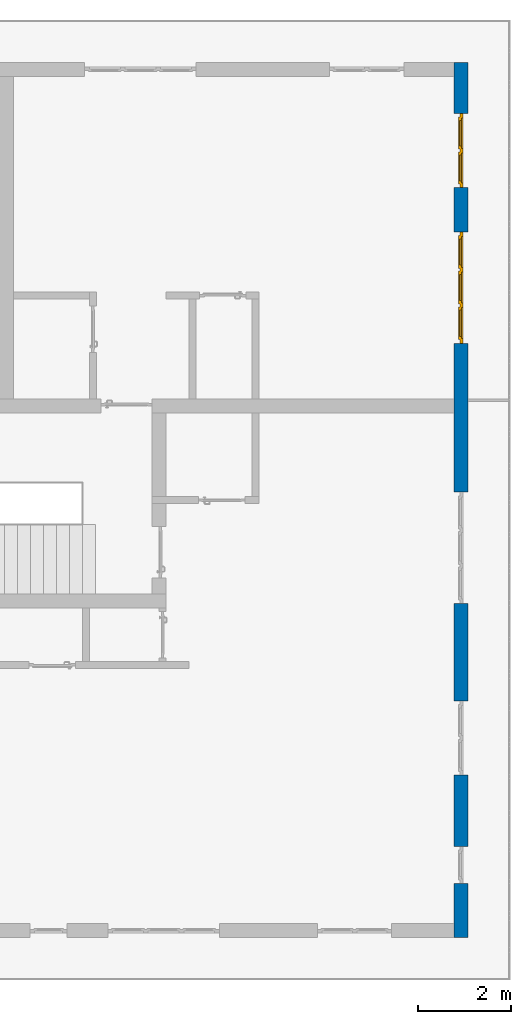
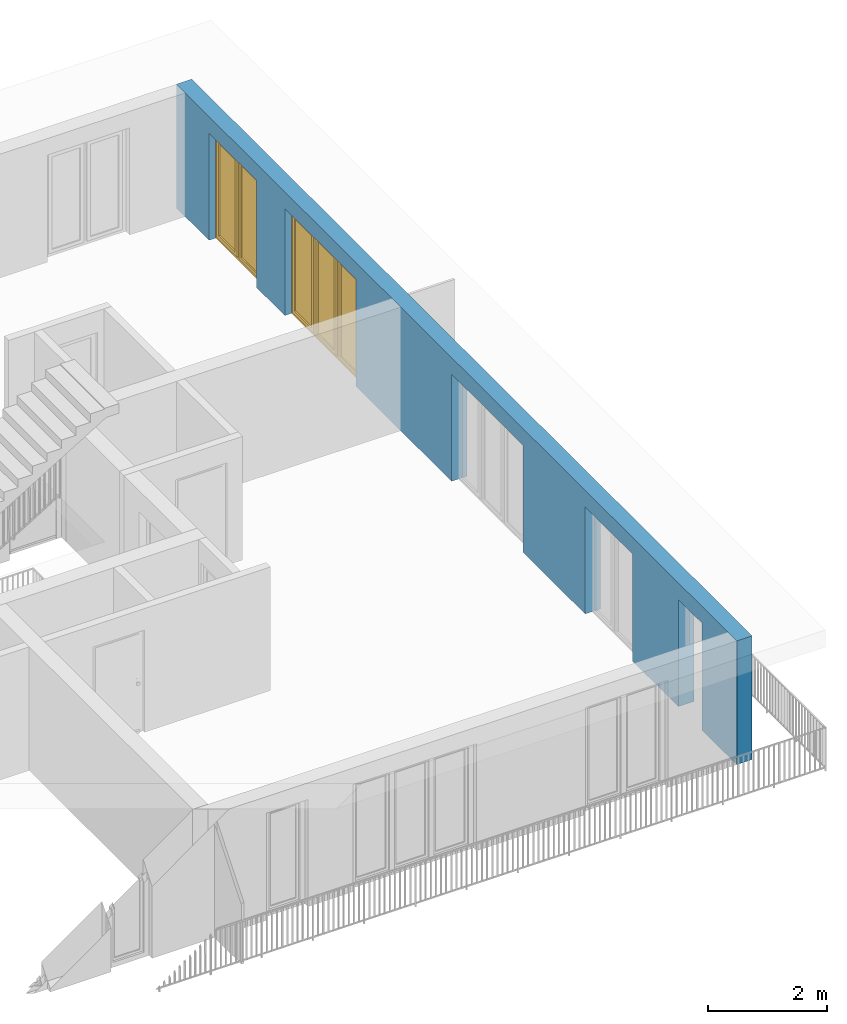
# One storey, part 17 of 48: 2 windows, 1 wall, 5 openings.
"""IFC4 building model written with IfcOpenShell, lengths in metres."""

from ifc_helpers import new_model, entity, si_unit, converted_unit, derived_unit, direction, frame, origin_with_axes, place, context, subcontext, project, spatial, polygons, source, transform, mapped, material, type_object, element, fill, save


model = new_model("IFC4")

# Units and contexts
model_context = context("Model", 3, precision=1e-05, world=origin_with_axes(), true_north=direction((0.0, 1.0)))
body_context = subcontext(model_context, "Body", "Model", "MODEL_VIEW")
ifc_project = project(units=[si_unit("LENGTHUNIT", "METRE"), si_unit("AREAUNIT", "SQUARE_METRE"), si_unit("VOLUMEUNIT", "CUBIC_METRE"), converted_unit("PLANEANGLEUNIT", "DEGREE", entity("IfcPlaneAngleMeasure", 0.0174532925199), si_unit("PLANEANGLEUNIT", "RADIAN"), dimensions=[0, 0, 0, 0, 0, 0, 0]), converted_unit("TIMEUNIT", "Year", entity("IfcTimeMeasure", 31556926.0), si_unit("TIMEUNIT", "SECOND"), dimensions=[0, 0, 1, 0, 0, 0, 0]), si_unit("MASSUNIT", "GRAM", prefix="KILO"), si_unit("THERMODYNAMICTEMPERATUREUNIT", "DEGREE_CELSIUS"), si_unit("LUMINOUSINTENSITYUNIT", "LUMEN"), si_unit("ENERGYUNIT", "JOULE", prefix="MEGA"), derived_unit("THERMALCONDUCTANCEUNIT", [(si_unit("POWERUNIT", "WATT"), 1), (si_unit("LENGTHUNIT", "METRE"), -1), (si_unit("THERMODYNAMICTEMPERATUREUNIT", "KELVIN"), -1)]), derived_unit("SPECIFICHEATCAPACITYUNIT", [(si_unit("ENERGYUNIT", "JOULE"), 1), (si_unit("MASSUNIT", "GRAM", prefix="KILO"), -1), (si_unit("THERMODYNAMICTEMPERATUREUNIT", "KELVIN"), -1)]), derived_unit("MASSDENSITYUNIT", [(si_unit("MASSUNIT", "GRAM", prefix="KILO"), 1), (si_unit("VOLUMEUNIT", "CUBIC_METRE"), -1)])], contexts=[model_context])

# Site, building, storey
site_placement = place(None, origin_with_axes())
site = spatial("IfcSite", under=ifc_project, at=site_placement, CompositionType="ELEMENT")
building_placement = place(site_placement, origin_with_axes())
building = spatial("IfcBuilding", under=site, at=building_placement, CompositionType="ELEMENT")
storey_placement = place(building_placement, frame((0.0, 0.0, 3.4), z_axis=(0.0, 0.0, 1.0), x_axis=(1.0, 0.0, 0.0)))
storey = spatial("IfcBuildingStorey", under=building, at=storey_placement, Name="1. Geschoss", CompositionType="ELEMENT", Elevation=3.4)

# Wall, openings, windows
ifc_material = material()
wall_type = type_object("IfcWallType", Name="300", PredefinedType="NOTDEFINED")
wall_placement = place(storey_placement, frame((9.3378006196, -9.92881223104, 0.0), z_axis=(0.0, 0.0, 1.0), x_axis=(0.0, 1.0, 0.0)))
wall = element("IfcWall", 1, at=wall_placement, inside=storey, type_object=wall_type, material=ifc_material, Name="Wand-001", PredefinedType="NOTDEFINED", context=body_context, shape_type="Tessellation", body=[
    polygons([(1.16441876325, 0.1, 2.2), (1.96441876325, 0.1, 2.2), (1.96441876325, 0.0, 2.2), (1.16441876325, 0.0, 2.2), (1.16441876325, 0.3, 2.2), (1.96441876325, 0.3, 2.2), (1.96441876325, 0.1, 0.0), (1.96441876325, 0.0, 0.0), (18.85, 0.0, 2.54), (0.0, 0.0, 2.54), (0.0, 0.0, 0.0), (1.16441876325, 0.0, 0.0), (3.5, 0.0, 0.0), (3.5, 0.0, 2.2), (5.1, 0.0, 2.2), (5.1, 0.0, 0.0), (7.1921181063, 0.0, 0.0), (7.1921181063, 0.0, 2.2), (9.5921181063, 0.0, 2.2), (9.5921181063, 0.0, 0.0), (12.8, 0.0, 0.0), (12.8, 0.0, 2.2), (15.2, 0.0, 2.2), (15.2, 0.0, 0.0), (16.15, 0.0, 0.0), (16.15, 0.0, 2.2), (17.75, 0.0, 2.2), (17.75, 0.0, 0.0), (18.85, 0.0, 0.0), (1.16441876325, 0.1, 0.0), (1.16441876325, 0.3, 0.0), (0.0, 0.3, 0.0), (0.0, 0.3, 2.54), (18.85, 0.3, 2.54), (18.85, 0.3, 0.0), (17.75, 0.3, 0.0), (17.75, 0.3, 2.2), (16.15, 0.3, 2.2), (16.15, 0.3, 0.0), (15.2, 0.3, 0.0), (15.2, 0.3, 2.2), (12.8, 0.3, 2.2), (12.8, 0.3, 0.0), (9.5921181063, 0.3, 0.0), (9.5921181063, 0.3, 2.2), (7.1921181063, 0.3, 2.2), (7.1921181063, 0.3, 0.0), (5.1, 0.3, 0.0), (5.1, 0.3, 2.2), (3.5, 0.3, 2.2), (3.5, 0.3, 0.0), (1.96441876325, 0.3, 0.0), (3.5, 0.1, 0.0), (3.5, 0.1, 2.2), (5.1, 0.1, 2.2), (5.1, 0.1, 0.0), (7.1921181063, 0.1, 0.0), (7.1921181063, 0.1, 2.2), (9.5921181063, 0.1, 2.2), (9.5921181063, 0.1, 0.0), (12.8, 0.1, 0.0), (12.8, 0.1, 2.2), (15.2, 0.1, 2.2), (15.2, 0.1, 0.0), (16.15, 0.1, 0.0), (16.15, 0.1, 2.2), (17.75, 0.1, 2.2), (17.75, 0.1, 0.0)], [[[1, 2, 3, 4]], [[2, 1, 5, 6]], [[2, 7, 8, 3]], [[9, 10, 11, 12, 4, 3, 8, 13, 14, 15, 16, 17, 18, 19, 20, 21, 22, 23, 24, 25, 26, 27, 28, 29]], [[30, 1, 4, 12]], [[1, 30, 31, 5]], [[5, 31, 32, 33, 34, 35, 36, 37, 38, 39, 40, 41, 42, 43, 44, 45, 46, 47, 48, 49, 50, 51, 52, 6]], [[7, 2, 6, 52]], [[7, 52, 51, 53, 13, 8]], [[9, 34, 33, 10]], [[33, 32, 11, 10]], [[31, 30, 12, 11, 32]], [[14, 13, 53, 54]], [[15, 14, 54, 55]], [[16, 15, 55, 56]], [[56, 48, 47, 57, 17, 16]], [[57, 58, 18, 17]], [[58, 59, 19, 18]], [[59, 60, 20, 19]], [[60, 44, 43, 61, 21, 20]], [[22, 21, 61, 62]], [[23, 22, 62, 63]], [[24, 23, 63, 64]], [[64, 40, 39, 65, 25, 24]], [[65, 66, 26, 25]], [[66, 67, 27, 26]], [[67, 68, 28, 27]], [[36, 35, 29, 28, 68]], [[9, 29, 35, 34]], [[68, 67, 37, 36]], [[67, 66, 38, 37]], [[66, 65, 39, 38]], [[41, 40, 64, 63]], [[42, 41, 63, 62]], [[43, 42, 62, 61]], [[60, 59, 45, 44]], [[59, 58, 46, 45]], [[58, 57, 47, 46]], [[49, 48, 56, 55]], [[50, 49, 55, 54]], [[51, 50, 54, 53]]], closed=True),
])
opening_1_placement = place(wall_placement, frame((16.95, 0.0, 0.0), z_axis=(0.0, 0.0, 1.0), x_axis=(1.0, 0.0, 0.0)))
opening_1 = element("IfcOpeningElement", 2, at=opening_1_placement, cuts=wall, Name="Fenster-001", context=body_context, identifier="Reference", shape_type="Tessellation", body=[
    polygons([(0.8, 0.1, 0.0), (0.8, 0.1, 2.2), (0.8, -0.000999999999999, 2.2), (0.8, -0.000999999999999, 0.0), (0.8, 0.301, 0.0), (0.8, 0.301, 2.2), (-0.8, 0.1, 2.2), (-0.8, -0.000999999999999, 2.2), (-0.8, 0.301, 2.2), (-0.8, -0.000999999999999, 0.0), (-0.8, 0.1, 0.0), (-0.8, 0.301, 0.0)], [[[1, 2, 3, 4]], [[2, 1, 5, 6]], [[7, 8, 3, 2, 6, 9]], [[8, 10, 4, 3]], [[1, 4, 10, 11, 12, 5]], [[6, 5, 12, 9]], [[7, 11, 10, 8]], [[11, 7, 9, 12]]], closed=True),
])
opening_2_placement = place(wall_placement, frame((14.0, 0.0, 0.0), z_axis=(0.0, 0.0, 1.0), x_axis=(1.0, 0.0, 0.0)))
opening_2 = element("IfcOpeningElement", 3, at=opening_2_placement, cuts=wall, Name="Fenster-002", context=body_context, identifier="Reference", shape_type="Tessellation", body=[
    polygons([(1.2, 0.1, 0.0), (1.2, 0.1, 2.2), (1.2, -0.000999999999999, 2.2), (1.2, -0.000999999999999, 0.0), (1.2, 0.301, 0.0), (1.2, 0.301, 2.2), (-1.2, 0.1, 2.2), (-1.2, -0.000999999999999, 2.2), (-1.2, 0.301, 2.2), (-1.2, -0.000999999999999, 0.0), (-1.2, 0.1, 0.0), (-1.2, 0.301, 0.0)], [[[1, 2, 3, 4]], [[2, 1, 5, 6]], [[7, 8, 3, 2, 6, 9]], [[8, 10, 4, 3]], [[1, 4, 10, 11, 12, 5]], [[6, 5, 12, 9]], [[7, 11, 10, 8]], [[11, 7, 9, 12]]], closed=True),
])
opening_3_placement = place(wall_placement, frame((8.3921181063, 0.0, 0.0), z_axis=(0.0, 0.0, 1.0), x_axis=(1.0, 0.0, 0.0)))
element("IfcOpeningElement", 4, at=opening_3_placement, cuts=wall, Name="Fenster-002", context=body_context, identifier="Reference", shape_type="Tessellation", body=[
    polygons([(1.2, 0.1, 0.0), (1.2, 0.1, 2.2), (1.2, -0.000999999999999, 2.2), (1.2, -0.000999999999999, 0.0), (1.2, 0.301, 0.0), (1.2, 0.301, 2.2), (-1.2, 0.1, 2.2), (-1.2, -0.000999999999999, 2.2), (-1.2, 0.301, 2.2), (-1.2, -0.000999999999999, 0.0), (-1.2, 0.1, 0.0), (-1.2, 0.301, 0.0)], [[[1, 2, 3, 4]], [[2, 1, 5, 6]], [[7, 8, 3, 2, 6, 9]], [[8, 10, 4, 3]], [[1, 4, 10, 11, 12, 5]], [[6, 5, 12, 9]], [[7, 11, 10, 8]], [[11, 7, 9, 12]]], closed=True),
])
opening_4_placement = place(wall_placement, frame((4.3, 0.0, 0.0), z_axis=(0.0, 0.0, 1.0), x_axis=(1.0, 0.0, 0.0)))
element("IfcOpeningElement", 5, at=opening_4_placement, cuts=wall, Name="Fenster-001", context=body_context, identifier="Reference", shape_type="Tessellation", body=[
    polygons([(0.8, 0.1, 0.0), (0.8, 0.1, 2.2), (0.8, -0.000999999999999, 2.2), (0.8, -0.000999999999999, 0.0), (0.8, 0.301, 0.0), (0.8, 0.301, 2.2), (-0.8, 0.1, 2.2), (-0.8, -0.000999999999999, 2.2), (-0.8, 0.301, 2.2), (-0.8, -0.000999999999999, 0.0), (-0.8, 0.1, 0.0), (-0.8, 0.301, 0.0)], [[[1, 2, 3, 4]], [[2, 1, 5, 6]], [[7, 8, 3, 2, 6, 9]], [[8, 10, 4, 3]], [[1, 4, 10, 11, 12, 5]], [[6, 5, 12, 9]], [[7, 11, 10, 8]], [[11, 7, 9, 12]]], closed=True),
])
opening_5_placement = place(wall_placement, frame((1.56441876325, 0.0, 0.0), z_axis=(0.0, 0.0, 1.0), x_axis=(1.0, 0.0, 0.0)))
element("IfcOpeningElement", 6, at=opening_5_placement, cuts=wall, Name="Fenster-003", context=body_context, identifier="Reference", shape_type="Tessellation", body=[
    polygons([(0.4, 0.1, 0.0), (0.4, 0.1, 2.2), (0.4, -0.000999999999999, 2.2), (0.4, -0.000999999999999, 0.0), (0.4, 0.301, 0.0), (0.4, 0.301, 2.2), (-0.4, 0.1, 2.2), (-0.4, -0.000999999999999, 2.2), (-0.4, 0.301, 2.2), (-0.4, -0.000999999999999, 0.0), (-0.4, 0.1, 0.0), (-0.4, 0.301, 0.0)], [[[1, 2, 3, 4]], [[2, 1, 5, 6]], [[7, 8, 3, 2, 6, 9]], [[8, 10, 4, 3]], [[1, 4, 10, 11, 12, 5]], [[6, 5, 12, 9]], [[7, 11, 10, 8]], [[11, 7, 9, 12]]], closed=True),
])
window_type_1 = type_object("IfcWindowType", Name="2-1+1 26", PartitioningType="DOUBLE_PANEL_VERTICAL", PredefinedType="WINDOW")
shared_shape_1 = source(origin_with_axes(), body_context, "Body", "Tessellation", [
    polygons([(-0.8, -0.07, 0.0), (-0.8, 0.0, 0.0), (-0.7, 0.0, 0.1), (-0.7, -0.07, 0.1), (-0.8, -0.07, 2.2), (-0.8, 0.0, 2.2), (-0.7, 0.0, 2.1), (-0.7, -0.07, 2.1)], [[[1, 2, 3, 4]], [[5, 6, 2, 1]], [[2, 6, 7, 3]], [[4, 3, 7, 8]], [[1, 4, 8, 5]], [[8, 7, 6, 5]]], closed=True),
    polygons([(0.8, -0.07, 0.0), (0.8, 0.0, 0.0), (0.8, 0.0, 2.2), (0.8, -0.07, 2.2), (0.7, -0.07, 0.1), (0.7, 0.0, 0.1), (0.7, 0.0, 2.1), (0.7, -0.07, 2.1)], [[[1, 2, 3, 4]], [[5, 6, 2, 1]], [[2, 6, 7, 3]], [[4, 3, 7, 8]], [[1, 4, 8, 5]], [[8, 7, 6, 5]]], closed=True),
    polygons([(-0.8, -0.07, 0.0), (-0.8, 0.0, 0.0), (0.8, 0.0, 0.0), (0.8, -0.07, 0.0), (-0.7, -0.07, 0.1), (-0.7, 0.0, 0.1), (-0.05, 0.0, 0.1), (0.05, 0.0, 0.1), (0.7, 0.0, 0.1), (0.7, -0.07, 0.1), (0.05, -0.07, 0.1), (-0.05, -0.07, 0.1)], [[[1, 2, 3, 4]], [[5, 6, 2, 1]], [[2, 6, 7, 8, 9, 3]], [[4, 3, 9, 10]], [[1, 4, 10, 11, 12, 5]], [[12, 7, 6, 5]], [[11, 8, 7, 12]], [[10, 9, 8, 11]]], closed=True),
    polygons([(-0.8, -0.07, 2.2), (-0.8, 0.0, 2.2), (-0.7, 0.0, 2.1), (-0.7, -0.07, 2.1), (0.8, -0.07, 2.2), (0.8, 0.0, 2.2), (0.7, 0.0, 2.1), (0.05, 0.0, 2.1), (-0.05, 0.0, 2.1), (-0.05, -0.07, 2.1), (0.05, -0.07, 2.1), (0.7, -0.07, 2.1)], [[[1, 2, 3, 4]], [[5, 6, 2, 1]], [[2, 6, 7, 8, 9, 3]], [[4, 3, 9, 10]], [[1, 4, 10, 11, 12, 5]], [[12, 7, 6, 5]], [[11, 8, 7, 12]], [[10, 9, 8, 11]]], closed=True),
    polygons([(-0.05, -0.07, 0.1), (-0.05, 0.0, 0.1), (0.05, 0.0, 0.1), (0.05, -0.07, 0.1), (-0.05, -0.07, 2.1), (-0.05, 0.0, 2.1), (0.05, 0.0, 2.1), (0.05, -0.07, 2.1)], [[[1, 2, 3, 4]], [[5, 6, 2, 1]], [[2, 6, 7, 3]], [[4, 3, 7, 8]], [[1, 4, 8, 5]], [[8, 7, 6, 5]]], closed=True),
    polygons([(-0.72, 0.0, 0.08), (-0.72, 0.03, 0.08), (-0.65, 0.03, 0.15), (-0.65, 0.0, 0.15), (-0.72, 0.0, 2.12), (-0.72, 0.03, 2.12), (-0.65, 0.03, 2.05), (-0.65, 0.0, 2.05)], [[[1, 2, 3, 4]], [[5, 6, 2, 1]], [[2, 6, 7, 3]], [[4, 3, 7, 8]], [[1, 4, 8, 5]], [[8, 7, 6, 5]]], closed=True),
    polygons([(-0.03, 0.0, 0.08), (-0.1, 0.0, 0.15), (-0.1, 0.03, 0.15), (-0.03, 0.03, 0.08), (-0.03, 0.0, 2.12), (-0.1, 0.0, 2.05), (-0.1, 0.03, 2.05), (-0.03, 0.03, 2.12)], [[[1, 2, 3, 4]], [[1, 5, 6, 2]], [[2, 6, 7, 3]], [[4, 3, 7, 8]], [[5, 1, 4, 8]], [[6, 5, 8, 7]]], closed=True),
    polygons([(-0.72, 0.0, 0.08), (-0.72, 0.03, 0.08), (-0.03, 0.03, 0.08), (-0.03, 0.0, 0.08), (-0.65, 0.0, 0.15), (-0.65, 0.03, 0.15), (-0.1, 0.03, 0.15), (-0.1, 0.0, 0.15)], [[[1, 2, 3, 4]], [[5, 6, 2, 1]], [[2, 6, 7, 3]], [[4, 3, 7, 8]], [[1, 4, 8, 5]], [[8, 7, 6, 5]]], closed=True),
    polygons([(-0.72, 0.0, 2.12), (-0.03, 0.0, 2.12), (-0.03, 0.03, 2.12), (-0.72, 0.03, 2.12), (-0.65, 0.0, 2.05), (-0.1, 0.0, 2.05), (-0.1, 0.03, 2.05), (-0.65, 0.03, 2.05)], [[[1, 2, 3, 4]], [[1, 5, 6, 2]], [[2, 6, 7, 3]], [[4, 3, 7, 8]], [[5, 1, 4, 8]], [[6, 5, 8, 7]]], closed=True),
    polygons([(-0.7, -0.03, 0.1), (-0.7, 0.0, 0.1), (-0.65, 0.0, 0.15), (-0.65, -0.03, 0.15), (-0.7, -0.03, 2.1), (-0.7, 0.0, 2.1), (-0.65, 0.0, 2.05), (-0.65, -0.03, 2.05)], [[[1, 2, 3, 4]], [[5, 6, 2, 1]], [[2, 6, 7, 3]], [[4, 3, 7, 8]], [[1, 4, 8, 5]], [[8, 7, 6, 5]]], closed=True),
    polygons([(-0.05, -0.03, 0.1), (-0.1, -0.03, 0.15), (-0.1, 0.0, 0.15), (-0.05, 0.0, 0.1), (-0.05, -0.03, 2.1), (-0.1, -0.03, 2.05), (-0.1, 0.0, 2.05), (-0.05, 0.0, 2.1)], [[[1, 2, 3, 4]], [[1, 5, 6, 2]], [[2, 6, 7, 3]], [[4, 3, 7, 8]], [[5, 1, 4, 8]], [[6, 5, 8, 7]]], closed=True),
    polygons([(-0.7, -0.03, 0.1), (-0.7, 0.0, 0.1), (-0.05, 0.0, 0.1), (-0.05, -0.03, 0.1), (-0.65, -0.03, 0.15), (-0.65, 0.0, 0.15), (-0.1, 0.0, 0.15), (-0.1, -0.03, 0.15)], [[[1, 2, 3, 4]], [[5, 6, 2, 1]], [[2, 6, 7, 3]], [[4, 3, 7, 8]], [[1, 4, 8, 5]], [[8, 7, 6, 5]]], closed=True),
    polygons([(-0.7, -0.03, 2.1), (-0.05, -0.03, 2.1), (-0.05, 0.0, 2.1), (-0.7, 0.0, 2.1), (-0.65, -0.03, 2.05), (-0.1, -0.03, 2.05), (-0.1, 0.0, 2.05), (-0.65, 0.0, 2.05)], [[[1, 2, 3, 4]], [[1, 5, 6, 2]], [[2, 6, 7, 3]], [[4, 3, 7, 8]], [[5, 1, 4, 8]], [[6, 5, 8, 7]]], closed=True),
    polygons([(-0.65, -0.005, 0.15), (-0.65, 0.005, 0.15), (-0.1, 0.005, 0.15), (-0.1, -0.005, 0.15), (-0.65, -0.005, 2.05), (-0.65, 0.005, 2.05), (-0.1, 0.005, 2.05), (-0.1, -0.005, 2.05)], [[[1, 2, 3, 4]], [[5, 6, 2, 1]], [[2, 6, 7, 3]], [[4, 3, 7, 8]], [[1, 4, 8, 5]], [[8, 7, 6, 5]]], closed=True),
    polygons([(0.03, 0.0, 0.08), (0.03, 0.03, 0.08), (0.1, 0.03, 0.15), (0.1, 0.0, 0.15), (0.03, 0.0, 2.12), (0.03, 0.03, 2.12), (0.1, 0.03, 2.05), (0.1, 0.0, 2.05)], [[[1, 2, 3, 4]], [[5, 6, 2, 1]], [[2, 6, 7, 3]], [[4, 3, 7, 8]], [[1, 4, 8, 5]], [[8, 7, 6, 5]]], closed=True),
    polygons([(0.72, 0.0, 0.08), (0.65, 0.0, 0.15), (0.65, 0.03, 0.15), (0.72, 0.03, 0.08), (0.72, 0.0, 2.12), (0.65, 0.0, 2.05), (0.65, 0.03, 2.05), (0.72, 0.03, 2.12)], [[[1, 2, 3, 4]], [[1, 5, 6, 2]], [[2, 6, 7, 3]], [[4, 3, 7, 8]], [[5, 1, 4, 8]], [[6, 5, 8, 7]]], closed=True),
    polygons([(0.03, 0.0, 0.08), (0.03, 0.03, 0.08), (0.72, 0.03, 0.08), (0.72, 0.0, 0.08), (0.1, 0.0, 0.15), (0.1, 0.03, 0.15), (0.65, 0.03, 0.15), (0.65, 0.0, 0.15)], [[[1, 2, 3, 4]], [[5, 6, 2, 1]], [[2, 6, 7, 3]], [[4, 3, 7, 8]], [[1, 4, 8, 5]], [[8, 7, 6, 5]]], closed=True),
    polygons([(0.03, 0.0, 2.12), (0.72, 0.0, 2.12), (0.72, 0.03, 2.12), (0.03, 0.03, 2.12), (0.1, 0.0, 2.05), (0.65, 0.0, 2.05), (0.65, 0.03, 2.05), (0.1, 0.03, 2.05)], [[[1, 2, 3, 4]], [[1, 5, 6, 2]], [[2, 6, 7, 3]], [[4, 3, 7, 8]], [[5, 1, 4, 8]], [[6, 5, 8, 7]]], closed=True),
    polygons([(0.05, -0.03, 0.1), (0.05, 0.0, 0.1), (0.1, 0.0, 0.15), (0.1, -0.03, 0.15), (0.05, -0.03, 2.1), (0.05, 0.0, 2.1), (0.1, 0.0, 2.05), (0.1, -0.03, 2.05)], [[[1, 2, 3, 4]], [[5, 6, 2, 1]], [[2, 6, 7, 3]], [[4, 3, 7, 8]], [[1, 4, 8, 5]], [[8, 7, 6, 5]]], closed=True),
    polygons([(0.7, -0.03, 0.1), (0.65, -0.03, 0.15), (0.65, 0.0, 0.15), (0.7, 0.0, 0.1), (0.7, -0.03, 2.1), (0.65, -0.03, 2.05), (0.65, 0.0, 2.05), (0.7, 0.0, 2.1)], [[[1, 2, 3, 4]], [[1, 5, 6, 2]], [[2, 6, 7, 3]], [[4, 3, 7, 8]], [[5, 1, 4, 8]], [[6, 5, 8, 7]]], closed=True),
    polygons([(0.05, -0.03, 0.1), (0.05, 0.0, 0.1), (0.7, 0.0, 0.1), (0.7, -0.03, 0.1), (0.1, -0.03, 0.15), (0.1, 0.0, 0.15), (0.65, 0.0, 0.15), (0.65, -0.03, 0.15)], [[[1, 2, 3, 4]], [[5, 6, 2, 1]], [[2, 6, 7, 3]], [[4, 3, 7, 8]], [[1, 4, 8, 5]], [[8, 7, 6, 5]]], closed=True),
    polygons([(0.05, -0.03, 2.1), (0.7, -0.03, 2.1), (0.7, 0.0, 2.1), (0.05, 0.0, 2.1), (0.1, -0.03, 2.05), (0.65, -0.03, 2.05), (0.65, 0.0, 2.05), (0.1, 0.0, 2.05)], [[[1, 2, 3, 4]], [[1, 5, 6, 2]], [[2, 6, 7, 3]], [[4, 3, 7, 8]], [[5, 1, 4, 8]], [[6, 5, 8, 7]]], closed=True),
    polygons([(0.1, -0.005, 0.15), (0.1, 0.005, 0.15), (0.65, 0.005, 0.15), (0.65, -0.005, 0.15), (0.1, -0.005, 2.05), (0.1, 0.005, 2.05), (0.65, 0.005, 2.05), (0.65, -0.005, 2.05)], [[[1, 2, 3, 4]], [[5, 6, 2, 1]], [[2, 6, 7, 3]], [[4, 3, 7, 8]], [[1, 4, 8, 5]], [[8, 7, 6, 5]]], closed=True),
])
window_1_placement = place(opening_1_placement, frame((-0.8, 0.0, 0.0), z_axis=(0.0, 0.0, 1.0), x_axis=(1.0, 0.0, 0.0)))
window_1 = element("IfcWindow", 7, at=window_1_placement, inside=storey, type_object=window_type_1, Name="Fenster-001", OverallHeight=2.2, OverallWidth=1.6, PredefinedType="WINDOW", context=body_context, shape_type="MappedRepresentation", body=[
    mapped(shared_shape_1, transform((0.8, 0.17, 0.0))),
])
fill(opening_1, window_1)
window_type_2 = type_object("IfcWindowType", Name="3-1+1+1 26", PartitioningType="TRIPLE_PANEL_VERTICAL", PredefinedType="WINDOW")
shared_shape_2 = source(origin_with_axes(), body_context, "Body", "Tessellation", [
    polygons([(1.2, -0.07, 0.0), (1.1, -0.07, 0.1), (1.1, 0.0, 0.1), (1.2, 0.0, 0.0), (1.2, -0.07, 2.2), (1.1, -0.07, 2.1), (1.1, 0.0, 2.1), (1.2, 0.0, 2.2)], [[[1, 2, 3, 4]], [[1, 5, 6, 2]], [[2, 6, 7, 3]], [[4, 3, 7, 8]], [[5, 1, 4, 8]], [[6, 5, 8, 7]]], closed=True),
    polygons([(-1.2, -0.07, 0.0), (-1.2, -0.07, 2.2), (-1.2, 0.0, 2.2), (-1.2, 0.0, 0.0), (-1.1, -0.07, 0.1), (-1.1, -0.07, 2.1), (-1.1, 0.0, 2.1), (-1.1, 0.0, 0.1)], [[[1, 2, 3, 4]], [[1, 5, 6, 2]], [[2, 6, 7, 3]], [[4, 3, 7, 8]], [[5, 1, 4, 8]], [[6, 5, 8, 7]]], closed=True),
    polygons([(1.2, -0.07, 0.0), (-1.2, -0.07, 0.0), (-1.2, 0.0, 0.0), (1.2, 0.0, 0.0), (1.1, -0.07, 0.1), (0.433333333333, -0.07, 0.1), (0.333333333333, -0.07, 0.1), (-0.333333333333, -0.07, 0.1), (-0.433333333333, -0.07, 0.1), (-1.1, -0.07, 0.1), (-1.1, 0.0, 0.1), (-0.433333333333, 0.0, 0.1), (-0.333333333333, 0.0, 0.1), (0.333333333333, 0.0, 0.1), (0.433333333333, 0.0, 0.1), (1.1, 0.0, 0.1)], [[[1, 2, 3, 4]], [[1, 5, 6, 7, 8, 9, 10, 2]], [[2, 10, 11, 3]], [[4, 3, 11, 12, 13, 14, 15, 16]], [[5, 1, 4, 16]], [[6, 5, 16, 15]], [[7, 6, 15, 14]], [[8, 7, 14, 13]], [[9, 8, 13, 12]], [[10, 9, 12, 11]]], closed=True),
    polygons([(1.2, -0.07, 2.2), (1.1, -0.07, 2.1), (1.1, 0.0, 2.1), (1.2, 0.0, 2.2), (-1.2, -0.07, 2.2), (-1.1, -0.07, 2.1), (-0.433333333333, -0.07, 2.1), (-0.333333333333, -0.07, 2.1), (0.333333333333, -0.07, 2.1), (0.433333333333, -0.07, 2.1), (0.433333333333, 0.0, 2.1), (0.333333333333, 0.0, 2.1), (-0.333333333333, 0.0, 2.1), (-0.433333333333, 0.0, 2.1), (-1.1, 0.0, 2.1), (-1.2, 0.0, 2.2)], [[[1, 2, 3, 4]], [[1, 5, 6, 7, 8, 9, 10, 2]], [[2, 10, 11, 3]], [[4, 3, 11, 12, 13, 14, 15, 16]], [[5, 1, 4, 16]], [[6, 5, 16, 15]], [[7, 6, 15, 14]], [[8, 7, 14, 13]], [[9, 8, 13, 12]], [[10, 9, 12, 11]]], closed=True),
    polygons([(-0.333333333333, -0.07, 0.1), (-0.433333333333, -0.07, 0.1), (-0.433333333333, 0.0, 0.1), (-0.333333333333, 0.0, 0.1), (-0.333333333333, -0.07, 2.1), (-0.433333333333, -0.07, 2.1), (-0.433333333333, 0.0, 2.1), (-0.333333333333, 0.0, 2.1)], [[[1, 2, 3, 4]], [[1, 5, 6, 2]], [[2, 6, 7, 3]], [[4, 3, 7, 8]], [[5, 1, 4, 8]], [[6, 5, 8, 7]]], closed=True),
    polygons([(0.433333333333, -0.07, 0.1), (0.333333333333, -0.07, 0.1), (0.333333333333, 0.0, 0.1), (0.433333333333, 0.0, 0.1), (0.433333333333, -0.07, 2.1), (0.333333333333, -0.07, 2.1), (0.333333333333, 0.0, 2.1), (0.433333333333, 0.0, 2.1)], [[[1, 2, 3, 4]], [[1, 5, 6, 2]], [[2, 6, 7, 3]], [[4, 3, 7, 8]], [[5, 1, 4, 8]], [[6, 5, 8, 7]]], closed=True),
    polygons([(1.12, 0.0, 0.08), (1.05, 0.0, 0.15), (1.05, 0.03, 0.15), (1.12, 0.03, 0.08), (1.12, 0.0, 2.12), (1.05, 0.0, 2.05), (1.05, 0.03, 2.05), (1.12, 0.03, 2.12)], [[[1, 2, 3, 4]], [[1, 5, 6, 2]], [[2, 6, 7, 3]], [[4, 3, 7, 8]], [[5, 1, 4, 8]], [[6, 5, 8, 7]]], closed=True),
    polygons([(0.413333333333, 0.0, 0.08), (0.413333333333, 0.03, 0.08), (0.483333333333, 0.03, 0.15), (0.483333333333, 0.0, 0.15), (0.413333333333, 0.0, 2.12), (0.413333333333, 0.03, 2.12), (0.483333333333, 0.03, 2.05), (0.483333333333, 0.0, 2.05)], [[[1, 2, 3, 4]], [[5, 6, 2, 1]], [[2, 6, 7, 3]], [[4, 3, 7, 8]], [[1, 4, 8, 5]], [[8, 7, 6, 5]]], closed=True),
    polygons([(1.12, 0.0, 0.08), (0.413333333333, 0.0, 0.08), (0.413333333333, 0.03, 0.08), (1.12, 0.03, 0.08), (1.05, 0.0, 0.15), (0.483333333333, 0.0, 0.15), (0.483333333333, 0.03, 0.15), (1.05, 0.03, 0.15)], [[[1, 2, 3, 4]], [[1, 5, 6, 2]], [[2, 6, 7, 3]], [[4, 3, 7, 8]], [[5, 1, 4, 8]], [[6, 5, 8, 7]]], closed=True),
    polygons([(1.12, 0.0, 2.12), (1.12, 0.03, 2.12), (0.413333333333, 0.03, 2.12), (0.413333333333, 0.0, 2.12), (1.05, 0.0, 2.05), (1.05, 0.03, 2.05), (0.483333333333, 0.03, 2.05), (0.483333333333, 0.0, 2.05)], [[[1, 2, 3, 4]], [[5, 6, 2, 1]], [[2, 6, 7, 3]], [[4, 3, 7, 8]], [[1, 4, 8, 5]], [[8, 7, 6, 5]]], closed=True),
    polygons([(1.1, -0.03, 0.1), (1.05, -0.03, 0.15), (1.05, 0.0, 0.15), (1.1, 0.0, 0.1), (1.1, -0.03, 2.1), (1.05, -0.03, 2.05), (1.05, 0.0, 2.05), (1.1, 0.0, 2.1)], [[[1, 2, 3, 4]], [[1, 5, 6, 2]], [[2, 6, 7, 3]], [[4, 3, 7, 8]], [[5, 1, 4, 8]], [[6, 5, 8, 7]]], closed=True),
    polygons([(0.433333333333, -0.03, 0.1), (0.433333333333, 0.0, 0.1), (0.483333333333, 0.0, 0.15), (0.483333333333, -0.03, 0.15), (0.433333333333, -0.03, 2.1), (0.433333333333, 0.0, 2.1), (0.483333333333, 0.0, 2.05), (0.483333333333, -0.03, 2.05)], [[[1, 2, 3, 4]], [[5, 6, 2, 1]], [[2, 6, 7, 3]], [[4, 3, 7, 8]], [[1, 4, 8, 5]], [[8, 7, 6, 5]]], closed=True),
    polygons([(1.1, -0.03, 0.1), (0.433333333333, -0.03, 0.1), (0.433333333333, 0.0, 0.1), (1.1, 0.0, 0.1), (1.05, -0.03, 0.15), (0.483333333333, -0.03, 0.15), (0.483333333333, 0.0, 0.15), (1.05, 0.0, 0.15)], [[[1, 2, 3, 4]], [[1, 5, 6, 2]], [[2, 6, 7, 3]], [[4, 3, 7, 8]], [[5, 1, 4, 8]], [[6, 5, 8, 7]]], closed=True),
    polygons([(1.1, -0.03, 2.1), (1.1, 0.0, 2.1), (0.433333333333, 0.0, 2.1), (0.433333333333, -0.03, 2.1), (1.05, -0.03, 2.05), (1.05, 0.0, 2.05), (0.483333333333, 0.0, 2.05), (0.483333333333, -0.03, 2.05)], [[[1, 2, 3, 4]], [[5, 6, 2, 1]], [[2, 6, 7, 3]], [[4, 3, 7, 8]], [[1, 4, 8, 5]], [[8, 7, 6, 5]]], closed=True),
    polygons([(1.05, -0.005, 0.15), (0.483333333333, -0.005, 0.15), (0.483333333333, 0.005, 0.15), (1.05, 0.005, 0.15), (1.05, -0.005, 2.05), (0.483333333333, -0.005, 2.05), (0.483333333333, 0.005, 2.05), (1.05, 0.005, 2.05)], [[[1, 2, 3, 4]], [[1, 5, 6, 2]], [[2, 6, 7, 3]], [[4, 3, 7, 8]], [[5, 1, 4, 8]], [[6, 5, 8, 7]]], closed=True),
    polygons([(0.353333333333, 0.0, 0.08), (0.283333333333, 0.0, 0.15), (0.283333333333, 0.03, 0.15), (0.353333333333, 0.03, 0.08), (0.353333333333, 0.0, 2.12), (0.283333333333, 0.0, 2.05), (0.283333333333, 0.03, 2.05), (0.353333333333, 0.03, 2.12)], [[[1, 2, 3, 4]], [[1, 5, 6, 2]], [[2, 6, 7, 3]], [[4, 3, 7, 8]], [[5, 1, 4, 8]], [[6, 5, 8, 7]]], closed=True),
    polygons([(-0.353333333333, 0.0, 0.08), (-0.353333333333, 0.03, 0.08), (-0.283333333333, 0.03, 0.15), (-0.283333333333, 0.0, 0.15), (-0.353333333333, 0.0, 2.12), (-0.353333333333, 0.03, 2.12), (-0.283333333333, 0.03, 2.05), (-0.283333333333, 0.0, 2.05)], [[[1, 2, 3, 4]], [[5, 6, 2, 1]], [[2, 6, 7, 3]], [[4, 3, 7, 8]], [[1, 4, 8, 5]], [[8, 7, 6, 5]]], closed=True),
    polygons([(0.353333333333, 0.0, 0.08), (-0.353333333333, 0.0, 0.08), (-0.353333333333, 0.03, 0.08), (0.353333333333, 0.03, 0.08), (0.283333333333, 0.0, 0.15), (-0.283333333333, 0.0, 0.15), (-0.283333333333, 0.03, 0.15), (0.283333333333, 0.03, 0.15)], [[[1, 2, 3, 4]], [[1, 5, 6, 2]], [[2, 6, 7, 3]], [[4, 3, 7, 8]], [[5, 1, 4, 8]], [[6, 5, 8, 7]]], closed=True),
    polygons([(0.353333333333, 0.0, 2.12), (0.353333333333, 0.03, 2.12), (-0.353333333333, 0.03, 2.12), (-0.353333333333, 0.0, 2.12), (0.283333333333, 0.0, 2.05), (0.283333333333, 0.03, 2.05), (-0.283333333333, 0.03, 2.05), (-0.283333333333, 0.0, 2.05)], [[[1, 2, 3, 4]], [[5, 6, 2, 1]], [[2, 6, 7, 3]], [[4, 3, 7, 8]], [[1, 4, 8, 5]], [[8, 7, 6, 5]]], closed=True),
    polygons([(0.333333333333, -0.03, 0.1), (0.283333333333, -0.03, 0.15), (0.283333333333, 0.0, 0.15), (0.333333333333, 0.0, 0.1), (0.333333333333, -0.03, 2.1), (0.283333333333, -0.03, 2.05), (0.283333333333, 0.0, 2.05), (0.333333333333, 0.0, 2.1)], [[[1, 2, 3, 4]], [[1, 5, 6, 2]], [[2, 6, 7, 3]], [[4, 3, 7, 8]], [[5, 1, 4, 8]], [[6, 5, 8, 7]]], closed=True),
    polygons([(-0.333333333333, -0.03, 0.1), (-0.333333333333, 0.0, 0.1), (-0.283333333333, 0.0, 0.15), (-0.283333333333, -0.03, 0.15), (-0.333333333333, -0.03, 2.1), (-0.333333333333, 0.0, 2.1), (-0.283333333333, 0.0, 2.05), (-0.283333333333, -0.03, 2.05)], [[[1, 2, 3, 4]], [[5, 6, 2, 1]], [[2, 6, 7, 3]], [[4, 3, 7, 8]], [[1, 4, 8, 5]], [[8, 7, 6, 5]]], closed=True),
    polygons([(0.333333333333, -0.03, 0.1), (-0.333333333333, -0.03, 0.1), (-0.333333333333, 0.0, 0.1), (0.333333333333, 0.0, 0.1), (0.283333333333, -0.03, 0.15), (-0.283333333333, -0.03, 0.15), (-0.283333333333, 0.0, 0.15), (0.283333333333, 0.0, 0.15)], [[[1, 2, 3, 4]], [[1, 5, 6, 2]], [[2, 6, 7, 3]], [[4, 3, 7, 8]], [[5, 1, 4, 8]], [[6, 5, 8, 7]]], closed=True),
    polygons([(0.333333333333, -0.03, 2.1), (0.333333333333, 0.0, 2.1), (-0.333333333333, 0.0, 2.1), (-0.333333333333, -0.03, 2.1), (0.283333333333, -0.03, 2.05), (0.283333333333, 0.0, 2.05), (-0.283333333333, 0.0, 2.05), (-0.283333333333, -0.03, 2.05)], [[[1, 2, 3, 4]], [[5, 6, 2, 1]], [[2, 6, 7, 3]], [[4, 3, 7, 8]], [[1, 4, 8, 5]], [[8, 7, 6, 5]]], closed=True),
    polygons([(0.283333333333, -0.005, 0.15), (-0.283333333333, -0.005, 0.15), (-0.283333333333, 0.005, 0.15), (0.283333333333, 0.005, 0.15), (0.283333333333, -0.005, 2.05), (-0.283333333333, -0.005, 2.05), (-0.283333333333, 0.005, 2.05), (0.283333333333, 0.005, 2.05)], [[[1, 2, 3, 4]], [[1, 5, 6, 2]], [[2, 6, 7, 3]], [[4, 3, 7, 8]], [[5, 1, 4, 8]], [[6, 5, 8, 7]]], closed=True),
    polygons([(-0.413333333333, 0.0, 0.08), (-0.483333333333, 0.0, 0.15), (-0.483333333333, 0.03, 0.15), (-0.413333333333, 0.03, 0.08), (-0.413333333333, 0.0, 2.12), (-0.483333333333, 0.0, 2.05), (-0.483333333333, 0.03, 2.05), (-0.413333333333, 0.03, 2.12)], [[[1, 2, 3, 4]], [[1, 5, 6, 2]], [[2, 6, 7, 3]], [[4, 3, 7, 8]], [[5, 1, 4, 8]], [[6, 5, 8, 7]]], closed=True),
    polygons([(-1.12, 0.0, 0.08), (-1.12, 0.03, 0.08), (-1.05, 0.03, 0.15), (-1.05, 0.0, 0.15), (-1.12, 0.0, 2.12), (-1.12, 0.03, 2.12), (-1.05, 0.03, 2.05), (-1.05, 0.0, 2.05)], [[[1, 2, 3, 4]], [[5, 6, 2, 1]], [[2, 6, 7, 3]], [[4, 3, 7, 8]], [[1, 4, 8, 5]], [[8, 7, 6, 5]]], closed=True),
    polygons([(-0.413333333333, 0.0, 0.08), (-1.12, 0.0, 0.08), (-1.12, 0.03, 0.08), (-0.413333333333, 0.03, 0.08), (-0.483333333333, 0.0, 0.15), (-1.05, 0.0, 0.15), (-1.05, 0.03, 0.15), (-0.483333333333, 0.03, 0.15)], [[[1, 2, 3, 4]], [[1, 5, 6, 2]], [[2, 6, 7, 3]], [[4, 3, 7, 8]], [[5, 1, 4, 8]], [[6, 5, 8, 7]]], closed=True),
    polygons([(-0.413333333333, 0.0, 2.12), (-0.413333333333, 0.03, 2.12), (-1.12, 0.03, 2.12), (-1.12, 0.0, 2.12), (-0.483333333333, 0.0, 2.05), (-0.483333333333, 0.03, 2.05), (-1.05, 0.03, 2.05), (-1.05, 0.0, 2.05)], [[[1, 2, 3, 4]], [[5, 6, 2, 1]], [[2, 6, 7, 3]], [[4, 3, 7, 8]], [[1, 4, 8, 5]], [[8, 7, 6, 5]]], closed=True),
    polygons([(-0.433333333333, -0.03, 0.1), (-0.483333333333, -0.03, 0.15), (-0.483333333333, 0.0, 0.15), (-0.433333333333, 0.0, 0.1), (-0.433333333333, -0.03, 2.1), (-0.483333333333, -0.03, 2.05), (-0.483333333333, 0.0, 2.05), (-0.433333333333, 0.0, 2.1)], [[[1, 2, 3, 4]], [[1, 5, 6, 2]], [[2, 6, 7, 3]], [[4, 3, 7, 8]], [[5, 1, 4, 8]], [[6, 5, 8, 7]]], closed=True),
    polygons([(-1.1, -0.03, 0.1), (-1.1, 0.0, 0.1), (-1.05, 0.0, 0.15), (-1.05, -0.03, 0.15), (-1.1, -0.03, 2.1), (-1.1, 0.0, 2.1), (-1.05, 0.0, 2.05), (-1.05, -0.03, 2.05)], [[[1, 2, 3, 4]], [[5, 6, 2, 1]], [[2, 6, 7, 3]], [[4, 3, 7, 8]], [[1, 4, 8, 5]], [[8, 7, 6, 5]]], closed=True),
    polygons([(-0.433333333333, -0.03, 0.1), (-1.1, -0.03, 0.1), (-1.1, 0.0, 0.1), (-0.433333333333, 0.0, 0.1), (-0.483333333333, -0.03, 0.15), (-1.05, -0.03, 0.15), (-1.05, 0.0, 0.15), (-0.483333333333, 0.0, 0.15)], [[[1, 2, 3, 4]], [[1, 5, 6, 2]], [[2, 6, 7, 3]], [[4, 3, 7, 8]], [[5, 1, 4, 8]], [[6, 5, 8, 7]]], closed=True),
    polygons([(-0.433333333333, -0.03, 2.1), (-0.433333333333, 0.0, 2.1), (-1.1, 0.0, 2.1), (-1.1, -0.03, 2.1), (-0.483333333333, -0.03, 2.05), (-0.483333333333, 0.0, 2.05), (-1.05, 0.0, 2.05), (-1.05, -0.03, 2.05)], [[[1, 2, 3, 4]], [[5, 6, 2, 1]], [[2, 6, 7, 3]], [[4, 3, 7, 8]], [[1, 4, 8, 5]], [[8, 7, 6, 5]]], closed=True),
    polygons([(-0.483333333333, -0.005, 0.15), (-1.05, -0.005, 0.15), (-1.05, 0.005, 0.15), (-0.483333333333, 0.005, 0.15), (-0.483333333333, -0.005, 2.05), (-1.05, -0.005, 2.05), (-1.05, 0.005, 2.05), (-0.483333333333, 0.005, 2.05)], [[[1, 2, 3, 4]], [[1, 5, 6, 2]], [[2, 6, 7, 3]], [[4, 3, 7, 8]], [[5, 1, 4, 8]], [[6, 5, 8, 7]]], closed=True),
])
window_2_placement = place(opening_2_placement, frame((-1.2, 0.0, 0.0), z_axis=(0.0, 0.0, 1.0), x_axis=(1.0, 0.0, 0.0)))
window_2 = element("IfcWindow", 8, at=window_2_placement, inside=storey, type_object=window_type_2, Name="Fenster-002", OverallHeight=2.2, OverallWidth=2.4, PredefinedType="WINDOW", context=body_context, shape_type="MappedRepresentation", body=[
    mapped(shared_shape_2, transform((1.2, 0.17, 0.0))),
])
fill(opening_2, window_2)

save(model, "model.ifc")
